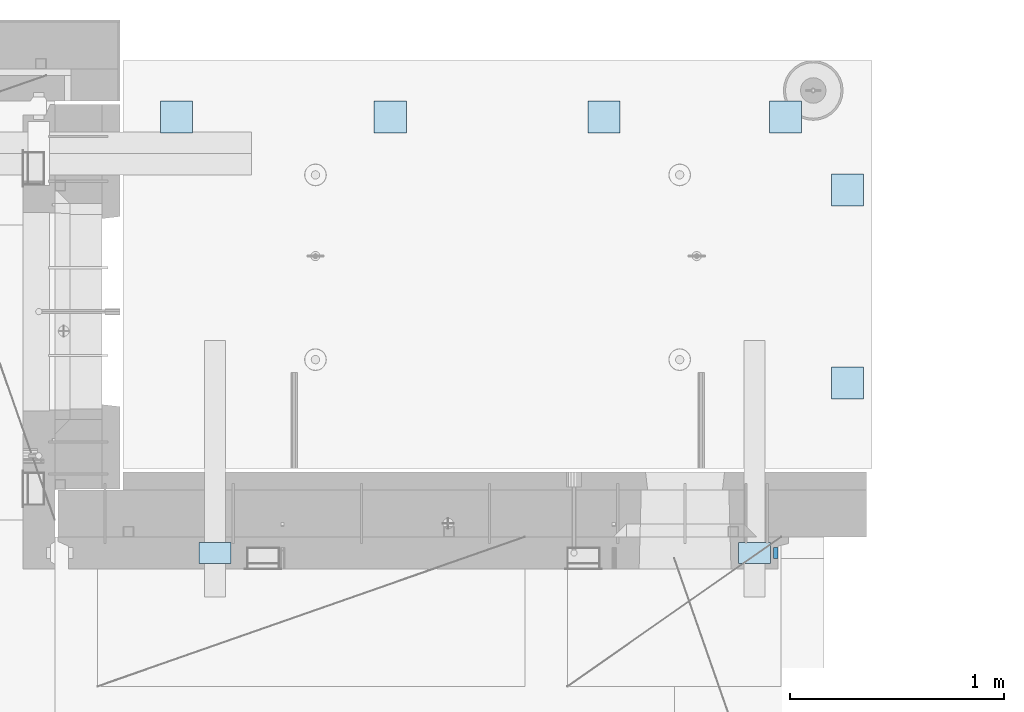
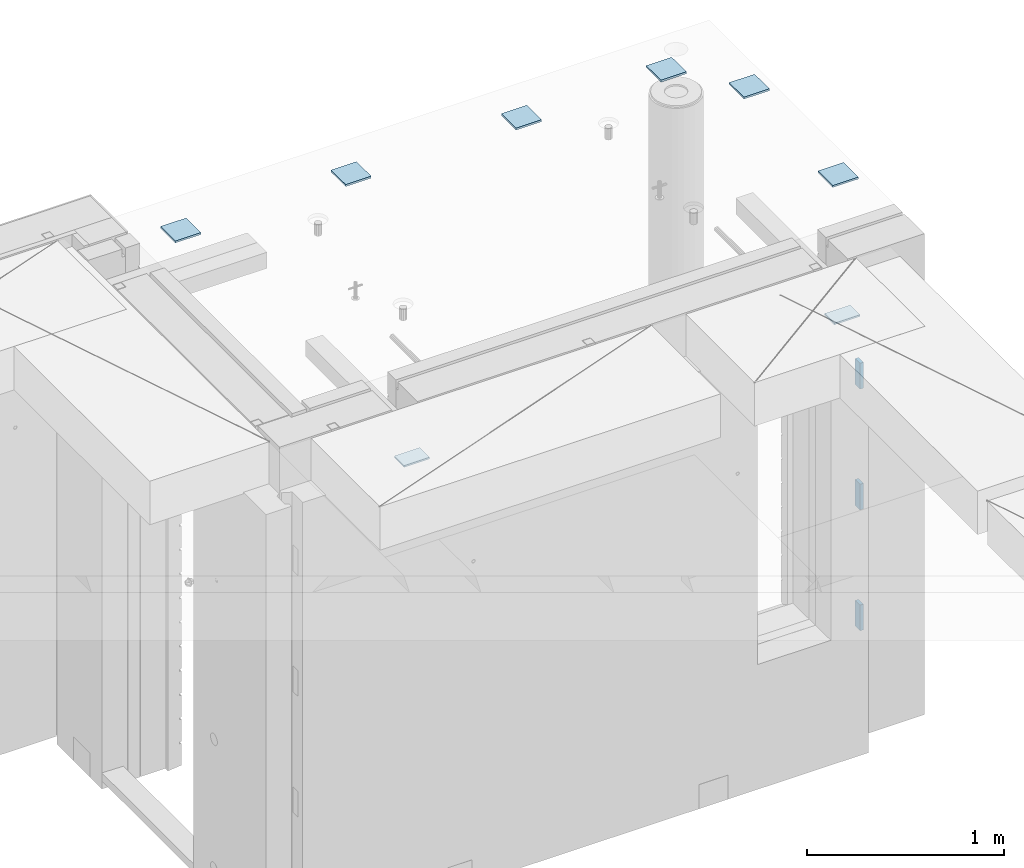
# One storey, part 191 of 309: 11 plates, 13 elements without a shape of their own.
"""IFC2X3 building model written with IfcOpenShell, lengths in millimetres."""

from ifc_helpers import new_model, si_unit, frame, origin_with_axes, place, context, subcontext, project, spatial, faceted_brep, material, type_object, element, aggregate, save


model = new_model("IFC2X3")

# Units and contexts
model_context = context("Model", 3, precision=1e-05, world=origin_with_axes())
body_context = subcontext(model_context, "Body", "Model", "MODEL_VIEW")
ifc_project = project(units=[si_unit("LENGTHUNIT", "METRE", prefix="MILLI"), si_unit("AREAUNIT", "SQUARE_METRE"), si_unit("VOLUMEUNIT", "CUBIC_METRE"), si_unit("MASSUNIT", "GRAM", prefix="KILO"), si_unit("TIMEUNIT", "SECOND"), si_unit("PLANEANGLEUNIT", "RADIAN"), si_unit("SOLIDANGLEUNIT", "STERADIAN"), si_unit("THERMODYNAMICTEMPERATUREUNIT", "DEGREE_CELSIUS"), si_unit("LUMINOUSINTENSITYUNIT", "LUMEN")], contexts=[model_context])

# Site, building, storey
site_placement = place(None, origin_with_axes())
site = spatial("IfcSite", under=ifc_project, at=site_placement, CompositionType="ELEMENT")
building_placement = place(site_placement, origin_with_axes())
building = spatial("IfcBuilding", under=site, at=building_placement, CompositionType="ELEMENT")
storey_placement = place(building_placement, origin_with_axes())
storey = spatial("IfcBuildingStorey", under=building, at=storey_placement, Name="7", CompositionType="ELEMENT", Elevation=0.0)

# Assemblies, plates
assembly_1_placement = place(storey_placement, origin_with_axes())
assembly_1 = element("IfcElementAssembly", 1, at=assembly_1_placement, inside=storey, AssemblyPlace="NOTDEFINED", PredefinedType="REINFORCEMENT_UNIT")
assembly_2_placement = place(assembly_1_placement, origin_with_axes())
assembly_2 = element("IfcElementAssembly", 2, at=assembly_2_placement, Name="Steel Assembly", AssemblyPlace="NOTDEFINED", PredefinedType="RIGID_FRAME")
ifc_material = material(Name="STEEL/Steel_Undefined")
plate_type_1 = type_object("IfcPlateType", PredefinedType="NOTDEFINED")
plate_1_placement = place(assembly_2_placement, frame((34825.0, 20479.9951872276, 102067.5), z_axis=(1.0, 0.0, 0.0), x_axis=(0.0, 1.0, 0.0)))
plate_1 = element("IfcPlate", 3, at=plate_1_placement, type_object=plate_type_1, material=ifc_material, Name="VL_080", context=body_context, shape_type="Brep", body=[
    faceted_brep([(0.0, -80.0, 0.0), (0.0, -80.0, 20.0), (0.0, 80.0, 20.0), (0.0, 80.0, 0.0), (50.0, -80.0, 20.0), (50.0, 80.0, 20.0), (50.0, -80.0, 0.0), (50.0, 80.0, 0.0)], [[[0, 1, 2, 3]], [[1, 4, 5, 2]], [[4, 6, 7, 5]], [[6, 0, 3, 7]], [[5, 7, 3, 2]], [[6, 4, 1, 0]]]),
])
aggregate(assembly_2, [plate_1])
assembly_3_placement = place(assembly_1_placement, origin_with_axes())
assembly_3 = element("IfcElementAssembly", 4, at=assembly_3_placement, Name="Steel Assembly", AssemblyPlace="NOTDEFINED", PredefinedType="RIGID_FRAME")
plate_2_placement = place(assembly_3_placement, frame((34825.0, 20479.9951872276, 101317.5), z_axis=(1.0, 0.0, 0.0), x_axis=(0.0, 1.0, 0.0)))
plate_2 = element("IfcPlate", 5, at=plate_2_placement, type_object=plate_type_1, material=ifc_material, Name="VL_080", context=body_context, shape_type="Brep", body=[
    faceted_brep([(0.0, -80.0, 0.0), (0.0, -80.0, 20.0), (0.0, 80.0, 20.0), (0.0, 80.0, 0.0), (50.0, -80.0, 20.0), (50.0, 80.0, 20.0), (50.0, -80.0, 0.0), (50.0, 80.0, 0.0)], [[[0, 1, 2, 3]], [[1, 4, 5, 2]], [[4, 6, 7, 5]], [[6, 0, 3, 7]], [[5, 7, 3, 2]], [[6, 4, 1, 0]]]),
])
aggregate(assembly_3, [plate_2])
assembly_4_placement = place(assembly_1_placement, origin_with_axes())
assembly_4 = element("IfcElementAssembly", 6, at=assembly_4_placement, Name="Steel Assembly", AssemblyPlace="NOTDEFINED", PredefinedType="RIGID_FRAME")
plate_3_placement = place(assembly_4_placement, frame((34825.0, 20479.9951872276, 100567.5), z_axis=(1.0, 0.0, 0.0), x_axis=(0.0, 1.0, 0.0)))
plate_3 = element("IfcPlate", 7, at=plate_3_placement, type_object=plate_type_1, material=ifc_material, Name="VL_080", context=body_context, shape_type="Brep", body=[
    faceted_brep([(0.0, -80.0, 0.0), (0.0, -80.0, 20.0), (0.0, 80.0, 20.0), (0.0, 80.0, 0.0), (50.0, -80.0, 20.0), (50.0, 80.0, 20.0), (50.0, -80.0, 0.0), (50.0, 80.0, 0.0)], [[[0, 1, 2, 3]], [[1, 4, 5, 2]], [[4, 6, 7, 5]], [[6, 0, 3, 7]], [[5, 7, 3, 2]], [[6, 4, 1, 0]]]),
])
aggregate(assembly_4, [plate_3])

assembly_5_placement = place(storey_placement, origin_with_axes())
assembly_5 = element("IfcElementAssembly", 8, at=assembly_5_placement, inside=storey, AssemblyPlace="NOTDEFINED", PredefinedType="REINFORCEMENT_UNIT")
assembly_6_placement = place(assembly_5_placement, origin_with_axes())
assembly_6 = element("IfcElementAssembly", 9, at=assembly_6_placement, Name="Steel Assembly", AssemblyPlace="NOTDEFINED", PredefinedType="RIGID_FRAME")
plate_type_2 = type_object("IfcPlateType", PredefinedType="NOTDEFINED")
plate_4_placement = place(assembly_6_placement, frame((35244.9972266744, 21375.0063306468, 102699.0), z_axis=(1.19800000174933e-06, -0.999999999999282, 0.0), x_axis=(-0.999999999997437, -2.26400000064461e-06, 0.0)))
plate_4 = element("IfcPlate", 10, at=plate_4_placement, type_object=plate_type_2, material=ifc_material, Name="150x150", context=body_context, shape_type="Brep", body=[
    faceted_brep([(0.0, -6.0, -1.45519152283669e-11), (-7.27595761418343e-12, -6.0, 150.000000000004), (-7.27595761418343e-12, 6.0, 150.000000000004), (0.0, 6.0, -1.45519152283669e-11), (149.999999999993, -6.0, 150.000000000004), (149.999999999993, 6.0, 150.000000000004), (149.999999999993, -6.0, 3.63797880709171e-12), (149.999999999993, 6.0, 3.63797880709171e-12)], [[[0, 1, 2, 3]], [[1, 4, 5, 2]], [[4, 6, 7, 5]], [[6, 0, 3, 7]], [[5, 7, 3, 2]], [[6, 4, 1, 0]]]),
])
aggregate(assembly_6, [plate_4])
assembly_7_placement = place(assembly_5_placement, origin_with_axes())
assembly_7 = element("IfcElementAssembly", 11, at=assembly_7_placement, Name="Steel Assembly", AssemblyPlace="NOTDEFINED", PredefinedType="RIGID_FRAME")
plate_5_placement = place(assembly_7_placement, frame((35244.9972266738, 22278.9063306473, 102699.0), z_axis=(1.19800000174933e-06, -0.999999999999282, 0.0), x_axis=(-0.999999999997437, -2.26400000064461e-06, 0.0)))
plate_5 = element("IfcPlate", 12, at=plate_5_placement, type_object=plate_type_2, material=ifc_material, Name="150x150", context=body_context, shape_type="Brep", body=[
    faceted_brep([(0.0, -6.0, -1.45519152283669e-11), (-7.27595761418343e-12, -6.0, 150.000000000004), (-7.27595761418343e-12, 6.0, 150.000000000004), (0.0, 6.0, -1.45519152283669e-11), (149.999999999993, -6.0, 150.000000000004), (149.999999999993, 6.0, 150.000000000004), (149.999999999993, -6.0, 3.63797880709171e-12), (149.999999999993, 6.0, 3.63797880709171e-12)], [[[0, 1, 2, 3]], [[1, 4, 5, 2]], [[4, 6, 7, 5]], [[6, 0, 3, 7]], [[5, 7, 3, 2]], [[6, 4, 1, 0]]]),
])
aggregate(assembly_7, [plate_5])
assembly_8_placement = place(assembly_5_placement, origin_with_axes())
assembly_8 = element("IfcElementAssembly", 13, at=assembly_8_placement, Name="Steel Assembly", AssemblyPlace="NOTDEFINED", PredefinedType="RIGID_FRAME")
plate_6_placement = place(assembly_8_placement, frame((34954.9972266738, 22620.0063306473, 102699.0), z_axis=(1.19800000174933e-06, -0.999999999999282, 0.0), x_axis=(-0.999999999997437, -2.26400000064461e-06, 0.0)))
plate_6 = element("IfcPlate", 14, at=plate_6_placement, type_object=plate_type_2, material=ifc_material, Name="150x150", context=body_context, shape_type="Brep", body=[
    faceted_brep([(0.0, -6.0, -1.45519152283669e-11), (-7.27595761418343e-12, -6.0, 150.000000000004), (-7.27595761418343e-12, 6.0, 150.000000000004), (0.0, 6.0, -1.45519152283669e-11), (149.999999999993, -6.0, 150.000000000004), (149.999999999993, 6.0, 150.000000000004), (149.999999999993, -6.0, 3.63797880709171e-12), (149.999999999993, 6.0, 3.63797880709171e-12)], [[[0, 1, 2, 3]], [[1, 4, 5, 2]], [[4, 6, 7, 5]], [[6, 0, 3, 7]], [[5, 7, 3, 2]], [[6, 4, 1, 0]]]),
])
aggregate(assembly_8, [plate_6])
assembly_9_placement = place(assembly_5_placement, origin_with_axes())
assembly_9 = element("IfcElementAssembly", 15, at=assembly_9_placement, Name="Steel Assembly", AssemblyPlace="NOTDEFINED", PredefinedType="RIGID_FRAME")
plate_7_placement = place(assembly_9_placement, frame((34104.9972266733, 22620.0063306479, 102699.0), z_axis=(1.19800000174933e-06, -0.999999999999282, 0.0), x_axis=(-0.999999999997437, -2.26400000064461e-06, 0.0)))
plate_7 = element("IfcPlate", 16, at=plate_7_placement, type_object=plate_type_2, material=ifc_material, Name="150x150", context=body_context, shape_type="Brep", body=[
    faceted_brep([(0.0, -6.0, -1.45519152283669e-11), (-7.27595761418343e-12, -6.0, 150.000000000004), (-7.27595761418343e-12, 6.0, 150.000000000004), (0.0, 6.0, -1.45519152283669e-11), (149.999999999993, -6.0, 150.000000000004), (149.999999999993, 6.0, 150.000000000004), (149.999999999993, -6.0, 3.63797880709171e-12), (149.999999999993, 6.0, 3.63797880709171e-12)], [[[0, 1, 2, 3]], [[1, 4, 5, 2]], [[4, 6, 7, 5]], [[6, 0, 3, 7]], [[5, 7, 3, 2]], [[6, 4, 1, 0]]]),
])
aggregate(assembly_9, [plate_7])
assembly_10_placement = place(assembly_5_placement, origin_with_axes())
assembly_10 = element("IfcElementAssembly", 17, at=assembly_10_placement, Name="Steel Assembly", AssemblyPlace="NOTDEFINED", PredefinedType="RIGID_FRAME")
plate_8_placement = place(assembly_10_placement, frame((33104.9972266733, 22620.0063306479, 102699.0), z_axis=(1.19800000174933e-06, -0.999999999999282, 0.0), x_axis=(-0.999999999997437, -2.26400000064461e-06, 0.0)))
plate_8 = element("IfcPlate", 18, at=plate_8_placement, type_object=plate_type_2, material=ifc_material, Name="150x150", context=body_context, shape_type="Brep", body=[
    faceted_brep([(0.0, -6.0, -1.45519152283669e-11), (-7.27595761418343e-12, -6.0, 150.000000000004), (-7.27595761418343e-12, 6.0, 150.000000000004), (0.0, 6.0, -1.45519152283669e-11), (149.999999999993, -6.0, 150.000000000004), (149.999999999993, 6.0, 150.000000000004), (149.999999999993, -6.0, 3.63797880709171e-12), (149.999999999993, 6.0, 3.63797880709171e-12)], [[[0, 1, 2, 3]], [[1, 4, 5, 2]], [[4, 6, 7, 5]], [[6, 0, 3, 7]], [[5, 7, 3, 2]], [[6, 4, 1, 0]]]),
])
aggregate(assembly_10, [plate_8])
assembly_11_placement = place(assembly_5_placement, origin_with_axes())
assembly_11 = element("IfcElementAssembly", 19, at=assembly_11_placement, Name="Steel Assembly", AssemblyPlace="NOTDEFINED", PredefinedType="RIGID_FRAME")
aggregate(assembly_5, [assembly_6, assembly_7, assembly_8, assembly_9, assembly_10, assembly_11])
plate_9_placement = place(assembly_11_placement, frame((32104.9972266727, 22620.0063306479, 102699.0), z_axis=(1.19800000174933e-06, -0.999999999999282, 0.0), x_axis=(-0.999999999997437, -2.26400000064461e-06, 0.0)))
plate_9 = element("IfcPlate", 20, at=plate_9_placement, type_object=plate_type_2, material=ifc_material, Name="150x150", context=body_context, shape_type="Brep", body=[
    faceted_brep([(0.0, -6.0, -1.45519152283669e-11), (-7.27595761418343e-12, -6.0, 150.000000000004), (-7.27595761418343e-12, 6.0, 150.000000000004), (0.0, 6.0, -1.45519152283669e-11), (149.999999999993, -6.0, 150.000000000004), (149.999999999993, 6.0, 150.000000000004), (149.999999999993, -6.0, 3.63797880709171e-12), (149.999999999993, 6.0, 3.63797880709171e-12)], [[[0, 1, 2, 3]], [[1, 4, 5, 2]], [[4, 6, 7, 5]], [[6, 0, 3, 7]], [[5, 7, 3, 2]], [[6, 4, 1, 0]]]),
])
aggregate(assembly_11, [plate_9])

# Assembly, plate
assembly_12_placement = place(assembly_1_placement, origin_with_axes())
assembly_12 = element("IfcElementAssembly", 21, at=assembly_12_placement, Name="Steel Assembly", AssemblyPlace="NOTDEFINED", PredefinedType="RIGID_FRAME")
plate_type_3 = type_object("IfcPlateType", PredefinedType="NOTDEFINED")
plate_10_placement = place(assembly_12_placement, frame((34810.0, 20454.9951872276, 102465.0), z_axis=(-1.0, 3.00000001838171e-08, 0.0), x_axis=(0.0, 1.0, 0.0)))
plate_10 = element("IfcPlate", 22, at=plate_10_placement, type_object=plate_type_3, material=ifc_material, Name="KL100x150", context=body_context, shape_type="Brep", body=[
    faceted_brep([(0.0, -5.0, 0.0), (7.27595761418343e-11, -5.0, 150.0), (7.27595761418343e-11, 5.0, 150.0), (0.0, 5.0, 0.0), (100.0, -5.0, 150.0), (100.0, 5.0, 150.0), (100.0, -5.0, 0.0), (100.0, 5.0, 0.0)], [[[0, 1, 2, 3]], [[1, 4, 5, 2]], [[4, 6, 7, 5]], [[6, 0, 3, 7]], [[5, 7, 3, 2]], [[6, 4, 1, 0]]]),
])
aggregate(assembly_12, [plate_10])

# Assembly
assembly_13_placement = place(assembly_1_placement, origin_with_axes())
assembly_13 = element("IfcElementAssembly", 23, at=assembly_13_placement, Name="Steel Assembly", AssemblyPlace="NOTDEFINED", PredefinedType="RIGID_FRAME")

aggregate(assembly_1, [assembly_2, assembly_3, assembly_4, assembly_12, assembly_13])

# Plate
plate_11_placement = place(assembly_13_placement, frame((32285.0, 20454.9951872276, 102465.0), z_axis=(-1.0, 3.00000001838171e-08, 0.0), x_axis=(0.0, 1.0, 0.0)))
plate_11 = element("IfcPlate", 24, at=plate_11_placement, type_object=plate_type_3, material=ifc_material, Name="KL100x150", context=body_context, shape_type="Brep", body=[
    faceted_brep([(0.0, -5.0, 0.0), (7.27595761418343e-11, -5.0, 150.0), (7.27595761418343e-11, 5.0, 150.0), (0.0, 5.0, 0.0), (100.0, -5.0, 150.0), (100.0, 5.0, 150.0), (100.0, -5.0, 0.0), (100.0, 5.0, 0.0)], [[[0, 1, 2, 3]], [[1, 4, 5, 2]], [[4, 6, 7, 5]], [[6, 0, 3, 7]], [[5, 7, 3, 2]], [[6, 4, 1, 0]]]),
])

aggregate(assembly_13, [plate_11])

save(model, "model.ifc")
